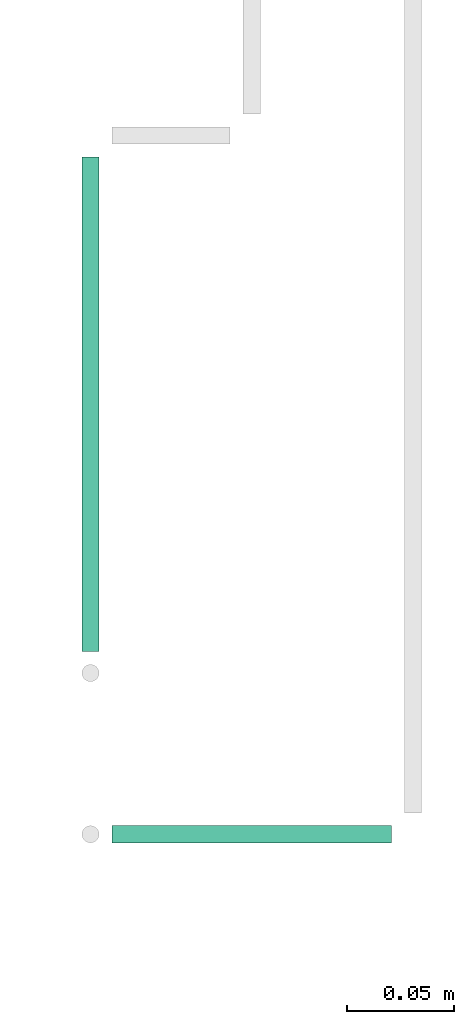
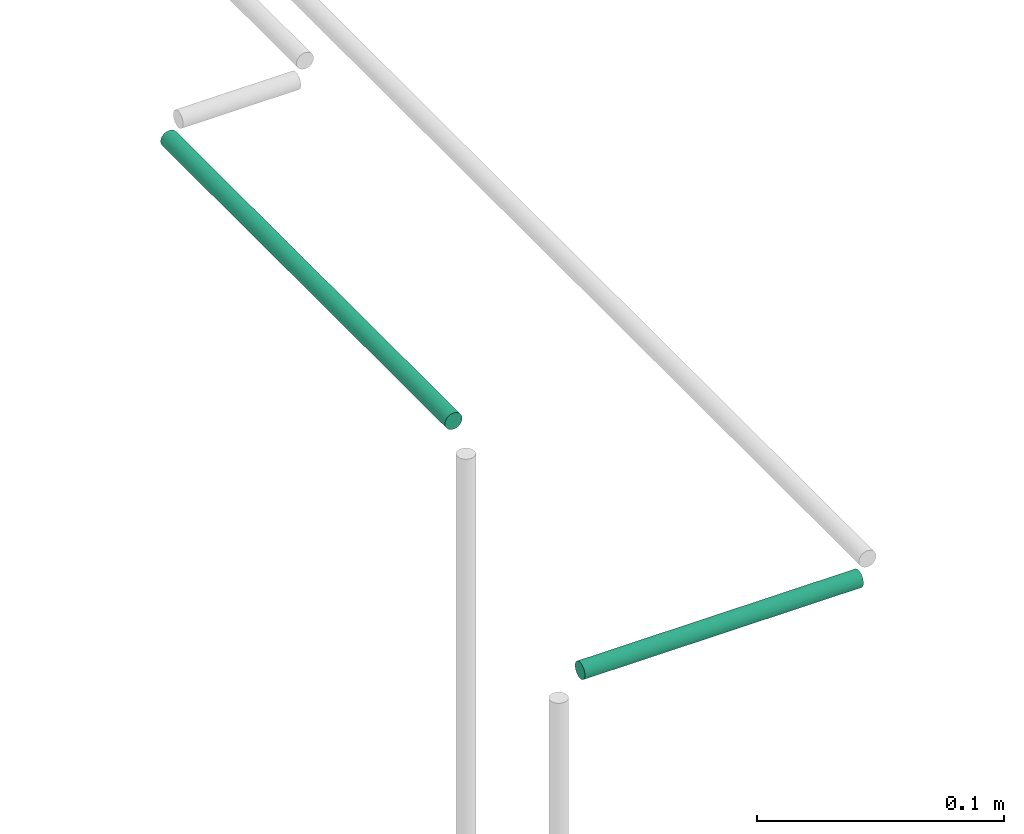
# One storey, part 54 of 89: 2 flow segments.
"""IFC2X3 building model written with IfcOpenShell, lengths in millimetres."""

from ifc_helpers import new_model, entity, si_unit, converted_unit, derived_unit, direction, frame, frame_2d, origin, origin_2d_with_axis, place, context, subcontext, project, spatial, circle, extrude, type_object, element, save


model = new_model("IFC2X3")

# Units and contexts
model_context = context("Model", 3, precision=0.01, world=origin(), true_north=direction((6.12303176911189e-17, 1.0)))
body_context = subcontext(model_context, "Body", "Model", "MODEL_VIEW")
ifc_project = project(units=[si_unit("LENGTHUNIT", "METRE", prefix="MILLI"), si_unit("AREAUNIT", "SQUARE_METRE"), si_unit("VOLUMEUNIT", "CUBIC_METRE"), converted_unit("PLANEANGLEUNIT", "DEGREE", entity("IfcRatioMeasure", 0.0174532925199433), si_unit("PLANEANGLEUNIT", "RADIAN"), dimensions=[0, 0, 0, 0, 0, 0, 0]), si_unit("MASSUNIT", "GRAM", prefix="KILO"), derived_unit("MASSDENSITYUNIT", [(si_unit("MASSUNIT", "GRAM", prefix="KILO"), 1), (si_unit("LENGTHUNIT", "METRE"), -3)]), derived_unit("MOMENTOFINERTIAUNIT", [(si_unit("LENGTHUNIT", "METRE"), 4)]), si_unit("TIMEUNIT", "SECOND"), si_unit("FREQUENCYUNIT", "HERTZ"), si_unit("THERMODYNAMICTEMPERATUREUNIT", "DEGREE_CELSIUS"), derived_unit("THERMALTRANSMITTANCEUNIT", [(si_unit("MASSUNIT", "GRAM", prefix="KILO"), 1), (si_unit("THERMODYNAMICTEMPERATUREUNIT", "KELVIN"), -1), (si_unit("TIMEUNIT", "SECOND"), -3)]), derived_unit("VOLUMETRICFLOWRATEUNIT", [(si_unit("LENGTHUNIT", "METRE"), 3), (si_unit("TIMEUNIT", "SECOND"), -1)]), derived_unit("MASSFLOWRATEUNIT", [(si_unit("MASSUNIT", "GRAM", prefix="KILO"), 1), (si_unit("TIMEUNIT", "SECOND"), -1)]), derived_unit("ROTATIONALFREQUENCYUNIT", [(si_unit("TIMEUNIT", "SECOND"), -1)]), si_unit("ELECTRICCURRENTUNIT", "AMPERE"), si_unit("ELECTRICVOLTAGEUNIT", "VOLT"), si_unit("POWERUNIT", "WATT"), si_unit("FORCEUNIT", "NEWTON", prefix="KILO"), si_unit("ILLUMINANCEUNIT", "LUX"), si_unit("LUMINOUSFLUXUNIT", "LUMEN"), si_unit("LUMINOUSINTENSITYUNIT", "CANDELA"), derived_unit("USERDEFINED", [(si_unit("MASSUNIT", "GRAM", prefix="KILO"), -1), (si_unit("LENGTHUNIT", "METRE"), -2), (si_unit("TIMEUNIT", "SECOND"), 3), (si_unit("LUMINOUSFLUXUNIT", "LUMEN"), 1)]), derived_unit("LINEARVELOCITYUNIT", [(si_unit("LENGTHUNIT", "METRE"), 1), (si_unit("TIMEUNIT", "SECOND"), -1)]), si_unit("PRESSUREUNIT", "PASCAL"), derived_unit("USERDEFINED", [(si_unit("LENGTHUNIT", "METRE"), -2), (si_unit("MASSUNIT", "GRAM", prefix="KILO"), 1), (si_unit("TIMEUNIT", "SECOND"), -2)]), derived_unit("LINEARFORCEUNIT", [(si_unit("MASSUNIT", "GRAM", prefix="KILO"), 1), (si_unit("LENGTHUNIT", "METRE"), 1), (si_unit("TIMEUNIT", "SECOND"), -2), (si_unit("LENGTHUNIT", "METRE"), -1)]), derived_unit("PLANARFORCEUNIT", [(si_unit("MASSUNIT", "GRAM", prefix="KILO"), 1), (si_unit("LENGTHUNIT", "METRE"), 1), (si_unit("TIMEUNIT", "SECOND"), -2), (si_unit("LENGTHUNIT", "METRE"), -2)])], contexts=[model_context])

# Site, building, storey
site_placement = place(None, frame((0.0, -0.00077364408347762, 0.0)))
site = spatial("IfcSite", under=ifc_project, at=site_placement, CompositionType="ELEMENT")
building_placement = place(site_placement, origin())
building = spatial("IfcBuilding", under=site, at=building_placement, CompositionType="ELEMENT")
storey_placement = place(building_placement, frame((0.0, 0.0, 24000.0)))
storey = spatial("IfcBuildingStorey", under=building, at=storey_placement, CompositionType="ELEMENT", Elevation=24000.0)

# Flow segments
pipe_segment_type = type_object("IfcPipeSegmentType", PredefinedType="NOTDEFINED")
flow_segment_1_placement = place(storey_placement, frame((53050.9046409091, 11569.4032812309, 3069.40472776409)))
element("IfcFlowSegment", 1, at=flow_segment_1_placement, inside=storey, type_object=pipe_segment_type, context=body_context, shape_type="SweptSolid", body=[
    extrude(circle(Radius=4.0, at=frame_2d((1.94916083273711e-11, 8.66293703438714e-12), x_axis=(1.0, 0.0))), frame((0.0, 5.59527223593448, 5.59527223592365), z_axis=(1.0, 0.0, 0.0), x_axis=(0.0, 1.0, 0.0)), (0.0, 0.0, 1.0), 130.000000000014),
])
flow_segment_2_placement = place(storey_placement, frame((53035.3093686732, 11659.9985534669, 3144.40472776409)))
element("IfcFlowSegment", 2, at=flow_segment_2_placement, inside=storey, type_object=pipe_segment_type, context=body_context, shape_type="SweptSolid", body=[
    extrude(circle(Radius=4.0, at=origin_2d_with_axis()), frame((5.59527223592365, 0.0, 5.59527223591499), z_axis=(0.0, 1.0, 0.0), x_axis=(1.0, 0.0, 0.0)), (0.0, 0.0, 1.0), 230.000000000004),
])

save(model, "model.ifc")
